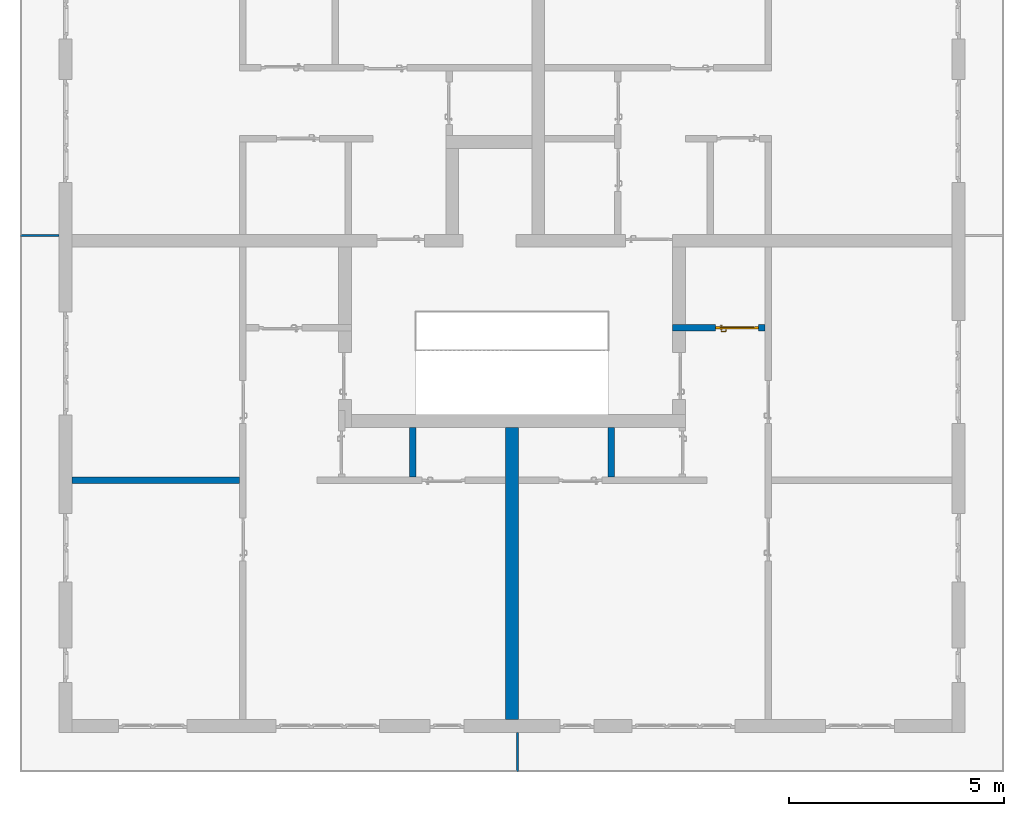
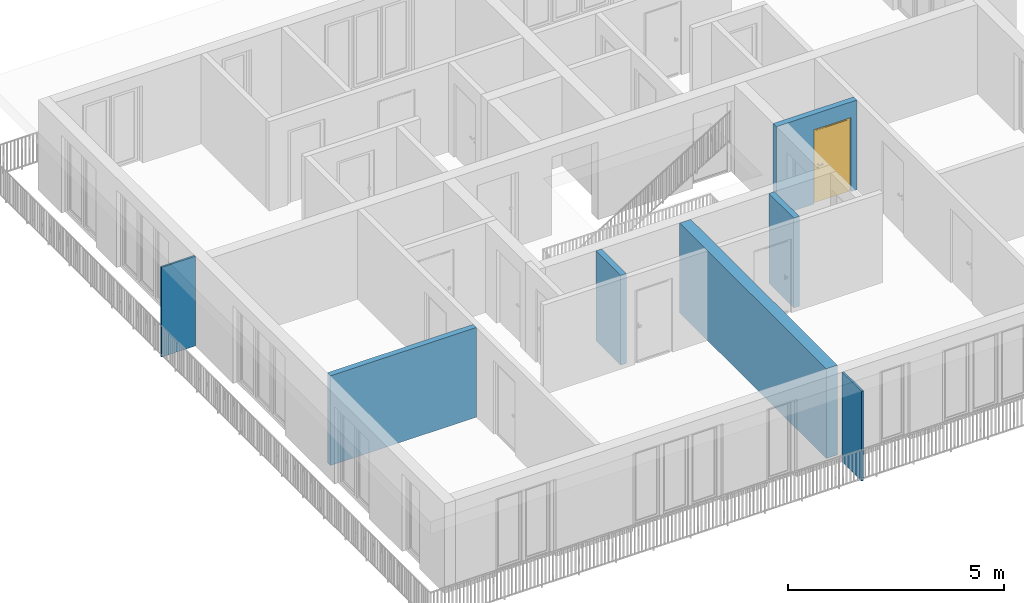
# One storey, part 7 of 54: 7 walls, 1 door, 1 opening.
"""IFC4 building model written with IfcOpenShell, lengths in metres."""

from ifc_helpers import new_model, entity, si_unit, converted_unit, derived_unit, direction, frame, origin_with_axes, place, context, subcontext, project, spatial, polygons, source, transform, mapped, material, type_object, element, fill, save


model = new_model("IFC4")

# Units and contexts
model_context = context("Model", 3, precision=1e-05, world=origin_with_axes(), true_north=direction((0.0, 1.0)))
body_context = subcontext(model_context, "Body", "Model", "MODEL_VIEW")
ifc_project = project(units=[si_unit("LENGTHUNIT", "METRE"), si_unit("AREAUNIT", "SQUARE_METRE"), si_unit("VOLUMEUNIT", "CUBIC_METRE"), converted_unit("PLANEANGLEUNIT", "DEGREE", entity("IfcPlaneAngleMeasure", 0.0174532925199), si_unit("PLANEANGLEUNIT", "RADIAN"), dimensions=[0, 0, 0, 0, 0, 0, 0]), converted_unit("TIMEUNIT", "Year", entity("IfcTimeMeasure", 31556926.0), si_unit("TIMEUNIT", "SECOND"), dimensions=[0, 0, 1, 0, 0, 0, 0]), si_unit("MASSUNIT", "GRAM", prefix="KILO"), si_unit("THERMODYNAMICTEMPERATUREUNIT", "DEGREE_CELSIUS"), si_unit("LUMINOUSINTENSITYUNIT", "LUMEN"), si_unit("ENERGYUNIT", "JOULE", prefix="MEGA"), derived_unit("THERMALCONDUCTANCEUNIT", [(si_unit("POWERUNIT", "WATT"), 1), (si_unit("LENGTHUNIT", "METRE"), -1), (si_unit("THERMODYNAMICTEMPERATUREUNIT", "KELVIN"), -1)]), derived_unit("SPECIFICHEATCAPACITYUNIT", [(si_unit("ENERGYUNIT", "JOULE"), 1), (si_unit("MASSUNIT", "GRAM", prefix="KILO"), -1), (si_unit("THERMODYNAMICTEMPERATUREUNIT", "KELVIN"), -1)]), derived_unit("MASSDENSITYUNIT", [(si_unit("MASSUNIT", "GRAM", prefix="KILO"), 1), (si_unit("VOLUMEUNIT", "CUBIC_METRE"), -1)])], contexts=[model_context])

# Site, building, storey
site_placement = place(None, origin_with_axes())
site = spatial("IfcSite", under=ifc_project, at=site_placement, CompositionType="ELEMENT")
building_placement = place(site_placement, origin_with_axes())
building = spatial("IfcBuilding", under=site, at=building_placement, CompositionType="ELEMENT")
storey_placement = place(building_placement, frame((0.0, 0.0, 6.29), z_axis=(0.0, 0.0, 1.0), x_axis=(1.0, 0.0, 0.0)))
storey = spatial("IfcBuildingStorey", under=building, at=storey_placement, Name="2. Geschoss", CompositionType="ELEMENT", Elevation=6.29)

# Walls
ifc_material_1 = material()
wall_type_1 = type_object("IfcWallType", Name="300", PredefinedType="NOTDEFINED")
wall_1_placement = place(storey_placement, frame((-1.2021993804, -2.52881223104, 0.0), z_axis=(0.0, 0.0, 1.0), x_axis=(0.0, -1.0, 0.0)))
element("IfcWall", 1, at=wall_1_placement, inside=storey, type_object=wall_type_1, material=ifc_material_1, Name="Wand-001", PredefinedType="NOTDEFINED", context=body_context, shape_type="Tessellation", body=[
    polygons([(0.3, -0.15, 0.0), (0.3, -0.15, 2.54), (0.3, 0.15, 2.54), (0.3, 0.15, 0.0), (7.1, -0.15, 0.0), (7.1, -0.15, 2.54), (7.1, 0.15, 2.54), (7.1, 0.15, 0.0)], [[[1, 2, 3, 4]], [[5, 6, 2, 1]], [[6, 7, 3, 2]], [[4, 3, 7, 8]], [[1, 4, 8, 5]], [[8, 7, 6, 5]]], closed=True),
])
wall_type_2 = type_object("IfcWallType", Name="150", PredefinedType="NOTDEFINED")
wall_2_placement = place(storey_placement, frame((-11.7421993804, -4.12881223104, 0.0), z_axis=(0.0, 0.0, 1.0), x_axis=(1.0, 0.0, 0.0)))
element("IfcWall", 2, at=wall_2_placement, inside=storey, type_object=wall_type_2, material=ifc_material_1, Name="Wand-004", PredefinedType="NOTDEFINED", context=body_context, shape_type="Tessellation", body=[
    polygons([(0.3, 0.15, 0.0), (0.3, 0.15, 2.54), (4.2, 0.15, 2.54), (4.2, 0.15, 0.0), (0.3, 0.0, 0.0), (0.3, 0.0, 2.54), (4.2, 0.0, 2.54), (4.2, 0.0, 0.0)], [[[1, 2, 3, 4]], [[5, 6, 2, 1]], [[6, 7, 3, 2]], [[4, 3, 7, 8]], [[1, 4, 8, 5]], [[8, 7, 6, 5]]], closed=True),
])
wall_3_placement = place(storey_placement, frame((-3.5921993804, -4.12881223104, 0.0), z_axis=(0.0, 0.0, 1.0), x_axis=(0.0, 1.0, 0.0)))
element("IfcWall", 3, at=wall_3_placement, inside=storey, type_object=wall_type_2, material=ifc_material_1, Name="Wand-002", PredefinedType="NOTDEFINED", context=body_context, shape_type="Tessellation", body=[
    polygons([(1.3, 0.0, 0.0), (1.3, 0.0, 2.54), (1.3, -0.15, 2.54), (1.3, -0.15, 0.0), (0.15, 0.0, 0.0), (0.15, 0.0, 2.54), (0.15, -0.15, 2.54), (0.15, -0.15, 0.0)], [[[1, 2, 3, 4]], [[5, 6, 2, 1]], [[6, 7, 3, 2]], [[4, 3, 7, 8]], [[5, 1, 4, 8]], [[8, 7, 6, 5]]], closed=True),
])
wall_4_placement = place(storey_placement, frame((1.1878006196, -4.12881223104, 0.0), z_axis=(0.0, 0.0, 1.0), x_axis=(0.0, 1.0, 0.0)))
element("IfcWall", 4, at=wall_4_placement, inside=storey, type_object=wall_type_2, material=ifc_material_1, Name="Wand-002", PredefinedType="NOTDEFINED", context=body_context, shape_type="Tessellation", body=[
    polygons([(1.3, 0.15, 0.0), (1.3, 0.15, 2.54), (1.3, 0.0, 2.54), (1.3, 0.0, 0.0), (0.15, 0.15, 0.0), (0.15, 0.15, 2.54), (0.15, 0.0, 2.54), (0.15, 0.0, 0.0)], [[[1, 2, 3, 4]], [[5, 6, 2, 1]], [[6, 7, 3, 2]], [[4, 3, 7, 8]], [[5, 1, 4, 8]], [[8, 7, 6, 5]]], closed=True),
])

# Wall, opening, door
wall_5_placement = place(storey_placement, frame((2.5378006196, -0.428812231043, 0.0), z_axis=(0.0, 0.0, 1.0), x_axis=(1.0, 0.0, 0.0)))
wall_5 = element("IfcWall", 5, at=wall_5_placement, inside=storey, type_object=wall_type_2, material=ifc_material_1, Name="Wand-002", PredefinedType="NOTDEFINED", context=body_context, shape_type="Tessellation", body=[
    polygons([(2.0, -0.05, 0.0), (2.0, -0.15, 0.0), (2.0, -0.15, 2.1), (2.0, 0.0, 2.1), (2.0, 0.0, 0.0), (2.15, 0.0, 0.0), (2.15, -0.15, 0.0), (2.15, -0.15, 2.54), (0.0, -0.15, 2.54), (0.0, -0.15, 0.0), (1.0, -0.15, 0.0), (1.0, -0.15, 2.1), (1.0, 0.0, 2.1), (1.0, 0.0, 0.0), (0.0, 0.0, 0.0), (0.0, 0.0, 2.54), (2.15, 0.0, 2.54), (1.0, -0.05, 0.0)], [[[1, 2, 3, 4, 5]], [[2, 1, 5, 6, 7]], [[3, 2, 7, 8, 9, 10, 11, 12]], [[4, 3, 12, 13]], [[6, 5, 4, 13, 14, 15, 16, 17]], [[8, 7, 6, 17]], [[17, 16, 9, 8]], [[16, 15, 10, 9]], [[18, 11, 10, 15, 14]], [[12, 11, 18, 14, 13]]], closed=True),
])
opening_placement = place(wall_5_placement, frame((1.5, 0.0, 0.0), z_axis=(0.0, 0.0, 1.0), x_axis=(1.0, 0.0, 0.0)))
opening = element("IfcOpeningElement", 6, at=opening_placement, cuts=wall_5, context=body_context, identifier="Reference", shape_type="Tessellation", body=[
    polygons([(-0.5, -0.05, 0.0), (-0.5, -0.05, 2.1), (-0.5, 0.001, 2.1), (-0.5, 0.001, 0.0), (-0.5, -0.151, 0.0), (-0.5, -0.151, 2.1), (0.5, -0.05, 2.1), (0.5, 0.001, 2.1), (0.5, -0.151, 2.1), (0.5, 0.001, 0.0), (0.5, -0.05, 0.0), (0.5, -0.151, 0.0)], [[[1, 2, 3, 4]], [[2, 1, 5, 6]], [[7, 8, 3, 2, 6, 9]], [[8, 10, 4, 3]], [[1, 4, 10, 11, 12, 5]], [[6, 5, 12, 9]], [[7, 11, 10, 8]], [[11, 7, 9, 12]]], closed=True),
])
door_type = type_object("IfcDoorType", Name="Eingang 01 1-Fl 26", OperationType="SINGLE_SWING_LEFT", PredefinedType="DOOR")
shared_shape = source(origin_with_axes(), body_context, "Body", "Tessellation", [
    polygons([(-0.5, -0.05, 0.0), (-0.5, -0.05, 2.1), (-0.5, -0.03, 2.1), (-0.5, -0.03, 0.0), (-0.4, -0.05, 0.0), (-0.4, -0.05, 2.0), (-0.1301, -0.05, 2.0), (-0.0001, -0.05, 2.0), (0.4, -0.05, 2.0), (0.4, -0.05, 0.0), (0.5, -0.05, 0.0), (0.5, -0.05, 2.1), (0.5, -0.03, 2.1), (0.5, -0.03, 0.0), (0.4, -0.03, 0.0), (0.4, -0.03, 2.0), (-0.0001, -0.03, 2.0), (-0.1301, -0.03, 2.0), (-0.4, -0.03, 2.0), (-0.4, -0.03, 0.0)], [[[1, 2, 3, 4]], [[1, 5, 6, 7, 8, 9, 10, 11, 12, 2]], [[2, 12, 13, 3]], [[4, 3, 13, 14, 15, 16, 17, 18, 19, 20]], [[5, 1, 4, 20]], [[6, 5, 20, 19]], [[7, 6, 19, 18]], [[8, 7, 18, 17]], [[9, 8, 17, 16]], [[10, 9, 16, 15]], [[11, 10, 15, 14]], [[12, 11, 14, 13]]], closed=True),
    polygons([(-0.5, -0.03, 0.0), (-0.5, -0.03, 2.1), (-0.5, 0.0, 2.1), (-0.5, 0.0, 0.0), (-0.43, -0.03, 0.0), (-0.43, -0.03, 2.03), (-0.1001, -0.03, 2.03), (-0.0301, -0.03, 2.03), (0.43, -0.03, 2.03), (0.43, -0.03, 0.0), (0.5, -0.03, 0.0), (0.5, -0.03, 2.1), (0.5, 0.0, 2.1), (0.5, 0.0, 0.0), (0.43, 0.0, 0.0), (0.43, 0.0, 2.03), (-0.0301, 0.0, 2.03), (-0.1001, 0.0, 2.03), (-0.43, 0.0, 2.03), (-0.43, 0.0, 0.0)], [[[1, 2, 3, 4]], [[1, 5, 6, 7, 8, 9, 10, 11, 12, 2]], [[2, 12, 13, 3]], [[4, 3, 13, 14, 15, 16, 17, 18, 19, 20]], [[5, 1, 4, 20]], [[6, 5, 20, 19]], [[7, 6, 19, 18]], [[8, 7, 18, 17]], [[9, 8, 17, 16]], [[10, 9, 16, 15]], [[11, 10, 15, 14]], [[12, 11, 14, 13]]], closed=True),
    polygons([(-0.43, 0.01, 0.0), (-0.43, 0.01, 2.03), (0.43, 0.01, 2.03), (0.43, 0.01, 0.0), (-0.43, -0.03, 0.0), (-0.43, -0.03, 2.03), (0.43, -0.03, 2.03), (0.43, -0.03, 0.0)], [[[1, 2, 3, 4]], [[1, 5, 6, 2]], [[2, 6, 7, 3]], [[3, 7, 8, 4]], [[4, 8, 5, 1]], [[8, 7, 6, 5]]], closed=True),
    polygons([(-0.395, -0.05, 0.0), (0.395, -0.05, 0.0), (0.395, -0.05, 0.05), (-0.395, -0.05, 0.05), (-0.395, -0.03, 0.0), (0.395, -0.03, 0.0), (0.395, -0.03, 0.07), (0.395, -0.035, 0.07), (-0.395, -0.035, 0.07), (-0.395, -0.03, 0.07)], [[[1, 2, 3, 4]], [[5, 6, 2, 1]], [[2, 6, 7, 8, 3]], [[4, 3, 8, 9]], [[1, 4, 9, 10, 5]], [[10, 7, 6, 5]], [[9, 8, 7, 10]]], closed=True),
    polygons([(0.3835, 0.02, 1.0733826859), (0.37, 0.02, 1.077), (0.37, 0.0199, 1.077), (0.3835, 0.0199, 1.0733826859), (0.393382685902, 0.02, 1.0635), (0.397, 0.02, 1.05), (0.393382685902, 0.02, 1.0365), (0.3835, 0.02, 1.0266173141), (0.37, 0.02, 1.023), (0.3565, 0.02, 1.0266173141), (0.346617314098, 0.02, 1.0365), (0.343, 0.02, 1.05), (0.346617314098, 0.02, 1.0635), (0.3565, 0.02, 1.0733826859), (0.3565, 0.0199, 1.0733826859), (0.37, 0.0101, 1.077), (0.3835, 0.0101, 1.0733826859), (0.393382685902, 0.0199, 1.0635), (0.397, 0.0199, 1.05), (0.393382685902, 0.0199, 1.0365), (0.3835, 0.0199, 1.0266173141), (0.37, 0.0199, 1.023), (0.3565, 0.0199, 1.0266173141), (0.346617314098, 0.0199, 1.0365), (0.343, 0.0199, 1.05), (0.346617314098, 0.0199, 1.0635), (0.3565, 0.0101, 1.0733826859), (0.37, 0.01, 1.077), (0.3835, 0.01, 1.0733826859), (0.393382685902, 0.0101, 1.0635), (0.397, 0.0101, 1.05), (0.393382685902, 0.0101, 1.0365), (0.3835, 0.0101, 1.0266173141), (0.37, 0.0101, 1.023), (0.3565, 0.0101, 1.0266173141), (0.346617314098, 0.0101, 1.0365), (0.343, 0.0101, 1.05), (0.346617314098, 0.0101, 1.0635), (0.3565, 0.01, 1.0733826859), (0.346617314098, 0.01, 1.0635), (0.343, 0.01, 1.05), (0.346617314098, 0.01, 1.0365), (0.3565, 0.01, 1.0266173141), (0.37, 0.01, 1.023), (0.3835, 0.01, 1.0266173141), (0.393382685902, 0.01, 1.0365), (0.397, 0.01, 1.05), (0.393382685902, 0.01, 1.0635)], [[[1, 2, 3, 4]], [[2, 1, 5, 6, 7, 8, 9, 10, 11, 12, 13, 14]], [[2, 14, 15, 3]], [[4, 3, 16, 17]], [[5, 1, 4, 18]], [[6, 5, 18, 19]], [[7, 6, 19, 20]], [[8, 7, 20, 21]], [[9, 8, 21, 22]], [[10, 9, 22, 23]], [[11, 10, 23, 24]], [[12, 11, 24, 25]], [[13, 12, 25, 26]], [[14, 13, 26, 15]], [[3, 15, 27, 16]], [[17, 16, 28, 29]], [[18, 4, 17, 30]], [[19, 18, 30, 31]], [[20, 19, 31, 32]], [[21, 20, 32, 33]], [[22, 21, 33, 34]], [[23, 22, 34, 35]], [[24, 23, 35, 36]], [[25, 24, 36, 37]], [[26, 25, 37, 38]], [[15, 26, 38, 27]], [[16, 27, 39, 28]], [[28, 39, 40, 41, 42, 43, 44, 45, 46, 47, 48, 29]], [[30, 17, 29, 48]], [[31, 30, 48, 47]], [[32, 31, 47, 46]], [[33, 32, 46, 45]], [[34, 33, 45, 44]], [[35, 34, 44, 43]], [[36, 35, 43, 42]], [[37, 36, 42, 41]], [[38, 37, 41, 40]], [[27, 38, 40, 39]]], closed=True),
    polygons([(0.362532169224, 0.019, 0.959692280177), (0.363279754556, 0.019, 0.961639806549), (0.35705, 0.019, 0.972430057958), (0.347569942042, 0.019, 0.96295), (0.365, 0.019, 0.952886751346), (0.365, 0.019, 0.9544), (0.362532169224, 0.02, 0.959692280177), (0.363279754556, 0.02, 0.961639806549), (0.364624817685, 0.02, 0.965143815798), (0.364624817685, 0.019, 0.965143815798), (0.37, 0.019, 0.967425445323), (0.37, 0.019, 0.9759), (0.357, 0.019, 0.972516660498), (0.347483339502, 0.019, 0.963), (0.365, 0.019, 0.95), (0.3441, 0.019, 0.95), (0.365, 0.019, 0.947113248654), (0.365, 0.019, 0.941339745962), (0.365, 0.019, 0.9375), (0.365, 0.02, 0.9375), (0.365, 0.02, 0.941339745962), (0.365, 0.02, 0.947113248654), (0.365, 0.02, 0.95), (0.365, 0.02, 0.952886751346), (0.365, 0.02, 0.9544), (0.346703916638, 0.02, 0.96345), (0.35655, 0.02, 0.973296083362), (0.37, 0.02, 0.9769), (0.37, 0.02, 0.967425445323), (0.375375182315, 0.019, 0.965143815798), (0.376720245444, 0.019, 0.961639806549), (0.38295, 0.019, 0.972430057958), (0.37, 0.019, 0.976), (0.357, 0.0189, 0.972516660498), (0.347483339502, 0.0189, 0.963), (0.344, 0.019, 0.95), (0.347569942042, 0.019, 0.93705), (0.35705, 0.019, 0.927569942042), (0.37, 0.019, 0.9241), (0.37, 0.019, 0.9325), (0.366464466094, 0.019, 0.933964466094), (0.366464466094, 0.02, 0.933964466094), (0.37, 0.02, 0.9231), (0.35655, 0.02, 0.926703916638), (0.37, 0.02, 0.9325), (0.346703916638, 0.02, 0.93655), (0.3431, 0.02, 0.95), (0.346617314098, 0.02, 0.9635), (0.3565, 0.02, 0.973382685902), (0.37, 0.02, 0.977), (0.375375182315, 0.02, 0.965143815798), (0.38345, 0.02, 0.973296083362), (0.376720245444, 0.02, 0.961639806549), (0.377467830776, 0.02, 0.959692280177), (0.377467830776, 0.019, 0.959692280177), (0.375, 0.019, 0.9544), (0.375, 0.019, 0.952886751346), (0.392430057958, 0.019, 0.96295), (0.383, 0.019, 0.972516660498), (0.37, 0.0189, 0.976), (0.357, 0.0101, 0.972516660498), (0.347483339502, 0.0101, 0.963), (0.344, 0.0189, 0.95), (0.347483339502, 0.019, 0.937), (0.357, 0.019, 0.927483339502), (0.37, 0.019, 0.924), (0.38295, 0.019, 0.927569942042), (0.375, 0.019, 0.941339745962), (0.375, 0.019, 0.9375), (0.373535533906, 0.019, 0.933964466094), (0.37, 0.02, 0.923), (0.3565, 0.02, 0.926617314098), (0.38345, 0.02, 0.926703916638), (0.373535533906, 0.02, 0.933964466094), (0.375, 0.02, 0.9375), (0.375, 0.02, 0.941339745962), (0.346617314098, 0.02, 0.9365), (0.343, 0.02, 0.95), (0.346617314098, 0.0199, 0.9635), (0.3565, 0.0199, 0.973382685902), (0.37, 0.0199, 0.977), (0.3835, 0.02, 0.973382685902), (0.393296083362, 0.02, 0.96345), (0.375, 0.02, 0.952886751346), (0.375, 0.02, 0.9544), (0.375, 0.02, 0.95), (0.375, 0.02, 0.947113248654), (0.375, 0.019, 0.947113248654), (0.375, 0.019, 0.95), (0.3959, 0.019, 0.95), (0.392516660498, 0.019, 0.963), (0.383, 0.0189, 0.972516660498), (0.37, 0.0101, 0.976), (0.357, 0.01, 0.972516660498), (0.347483339502, 0.01, 0.963), (0.344, 0.0101, 0.95), (0.347483339502, 0.0189, 0.937), (0.357, 0.0189, 0.927483339502), (0.37, 0.0189, 0.924), (0.383, 0.019, 0.927483339502), (0.392430057958, 0.019, 0.93705), (0.37, 0.0199, 0.923), (0.3565, 0.0199, 0.926617314098), (0.3835, 0.02, 0.926617314098), (0.393296083362, 0.02, 0.93655), (0.346617314098, 0.0199, 0.9365), (0.343, 0.0199, 0.95), (0.346617314098, 0.0101, 0.9635), (0.3565, 0.0101, 0.973382685902), (0.37, 0.0101, 0.977), (0.3835, 0.0199, 0.973382685902), (0.393382685902, 0.02, 0.9635), (0.3969, 0.02, 0.95), (0.396, 0.019, 0.95), (0.392516660498, 0.0189, 0.963), (0.383, 0.0101, 0.972516660498), (0.37, 0.01, 0.976), (0.35695, 0.01, 0.972603263039), (0.347396736961, 0.01, 0.96305), (0.344, 0.01, 0.95), (0.347483339502, 0.0101, 0.937), (0.357, 0.0101, 0.927483339502), (0.37, 0.0101, 0.924), (0.383, 0.0189, 0.927483339502), (0.392516660498, 0.019, 0.937), (0.37, 0.0101, 0.923), (0.3565, 0.0101, 0.926617314098), (0.3835, 0.0199, 0.926617314098), (0.393382685902, 0.02, 0.9365), (0.346617314098, 0.0101, 0.9365), (0.343, 0.0101, 0.95), (0.346617314098, 0.01, 0.9635), (0.3565, 0.01, 0.973382685902), (0.37, 0.01, 0.977), (0.3835, 0.0101, 0.973382685902), (0.393382685902, 0.0199, 0.9635), (0.397, 0.02, 0.95), (0.396, 0.0189, 0.95), (0.392516660498, 0.0101, 0.963), (0.383, 0.01, 0.972516660498), (0.37, 0.01, 0.9761), (0.35655, 0.01, 0.973296083362), (0.346703916638, 0.01, 0.96345), (0.3439, 0.01, 0.95), (0.347483339502, 0.01, 0.937), (0.357, 0.01, 0.927483339502), (0.37, 0.01, 0.924), (0.383, 0.0101, 0.927483339502), (0.392516660498, 0.0189, 0.937), (0.37, 0.01, 0.923), (0.3565, 0.01, 0.926617314098), (0.3835, 0.0101, 0.926617314098), (0.393382685902, 0.0199, 0.9365), (0.346617314098, 0.01, 0.9365), (0.343, 0.01, 0.95), (0.37, 0.01, 0.9769), (0.3835, 0.01, 0.973382685902), (0.393382685902, 0.0101, 0.9635), (0.397, 0.0199, 0.95), (0.396, 0.0101, 0.95), (0.392516660498, 0.01, 0.963), (0.38305, 0.01, 0.972603263039), (0.3431, 0.01, 0.95), (0.347396736961, 0.01, 0.93695), (0.35695, 0.01, 0.927396736961), (0.37, 0.01, 0.9239), (0.383, 0.01, 0.927483339502), (0.392516660498, 0.0101, 0.937), (0.37, 0.01, 0.9231), (0.35655, 0.01, 0.926703916638), (0.3835, 0.01, 0.926617314098), (0.393382685902, 0.0101, 0.9365), (0.346703916638, 0.01, 0.93655), (0.38345, 0.01, 0.973296083362), (0.393382685902, 0.01, 0.9635), (0.397, 0.0101, 0.95), (0.396, 0.01, 0.95), (0.392603263039, 0.01, 0.96305), (0.38305, 0.01, 0.927396736961), (0.392516660498, 0.01, 0.937), (0.38345, 0.01, 0.926703916638), (0.393382685902, 0.01, 0.9365), (0.393296083362, 0.01, 0.96345), (0.397, 0.01, 0.95), (0.3961, 0.01, 0.95), (0.392603263039, 0.01, 0.93695), (0.393296083362, 0.01, 0.93655), (0.3969, 0.01, 0.95)], [[[1, 2, 3, 4, 5, 6]], [[1, 7, 8, 9, 10, 2]], [[10, 11, 12, 3, 2]], [[4, 3, 13, 14]], [[15, 5, 4, 16]], [[6, 5, 15, 17, 18, 19, 20, 21, 22, 23, 24, 25]], [[6, 25, 7, 1]], [[7, 25, 24, 26, 27, 8]], [[9, 8, 27, 28, 29]], [[10, 9, 29, 11]], [[30, 31, 32, 12, 11]], [[3, 12, 33, 13]], [[14, 13, 34, 35]], [[16, 4, 14, 36]], [[17, 15, 16, 37]], [[18, 17, 37, 38]], [[38, 39, 40, 41, 19, 18]], [[19, 41, 42, 20]], [[43, 44, 21, 20, 42, 45]], [[22, 21, 44, 46]], [[23, 22, 46, 47]], [[24, 23, 47, 26]], [[48, 49, 27, 26]], [[49, 50, 28, 27]], [[51, 29, 28, 52, 53]], [[11, 29, 51, 30]], [[30, 51, 53, 54, 55, 31]], [[55, 56, 57, 58, 32, 31]], [[12, 32, 59, 33]], [[13, 33, 60, 34]], [[35, 34, 61, 62]], [[36, 14, 35, 63]], [[37, 16, 36, 64]], [[38, 37, 64, 65]], [[39, 38, 65, 66]], [[39, 67, 68, 69, 70, 40]], [[41, 40, 45, 42]], [[71, 72, 44, 43]], [[73, 43, 45, 74, 75, 76]], [[72, 77, 46, 44]], [[77, 78, 47, 46]], [[78, 48, 26, 47]], [[79, 80, 49, 48]], [[80, 81, 50, 49]], [[50, 82, 52, 28]], [[54, 53, 52, 83, 84, 85]], [[55, 54, 85, 56]], [[85, 84, 86, 87, 76, 75, 69, 68, 88, 89, 57, 56]], [[57, 89, 90, 58]], [[32, 58, 91, 59]], [[33, 59, 92, 60]], [[34, 60, 93, 61]], [[62, 61, 94, 95]], [[63, 35, 62, 96]], [[64, 36, 63, 97]], [[65, 64, 97, 98]], [[66, 65, 98, 99]], [[67, 39, 66, 100]], [[88, 68, 67, 101]], [[70, 69, 75, 74]], [[40, 70, 74, 45]], [[102, 103, 72, 71]], [[104, 71, 43, 73]], [[76, 87, 105, 73]], [[103, 106, 77, 72]], [[106, 107, 78, 77]], [[107, 79, 48, 78]], [[108, 109, 80, 79]], [[109, 110, 81, 80]], [[81, 111, 82, 50]], [[82, 112, 83, 52]], [[86, 84, 83, 113]], [[87, 86, 113, 105]], [[89, 88, 101, 90]], [[58, 90, 114, 91]], [[59, 91, 115, 92]], [[60, 92, 116, 93]], [[61, 93, 117, 94]], [[95, 94, 118, 119]], [[96, 62, 95, 120]], [[97, 63, 96, 121]], [[98, 97, 121, 122]], [[99, 98, 122, 123]], [[100, 66, 99, 124]], [[101, 67, 100, 125]], [[126, 127, 103, 102]], [[128, 102, 71, 104]], [[129, 104, 73, 105]], [[127, 130, 106, 103]], [[130, 131, 107, 106]], [[131, 108, 79, 107]], [[132, 133, 109, 108]], [[133, 134, 110, 109]], [[110, 135, 111, 81]], [[111, 136, 112, 82]], [[112, 137, 113, 83]], [[137, 129, 105, 113]], [[90, 101, 125, 114]], [[91, 114, 138, 115]], [[92, 115, 139, 116]], [[93, 116, 140, 117]], [[94, 117, 141, 118]], [[119, 118, 142, 143]], [[120, 95, 119, 144]], [[121, 96, 120, 145]], [[122, 121, 145, 146]], [[123, 122, 146, 147]], [[124, 99, 123, 148]], [[125, 100, 124, 149]], [[150, 151, 127, 126]], [[152, 126, 102, 128]], [[153, 128, 104, 129]], [[151, 154, 130, 127]], [[154, 155, 131, 130]], [[155, 132, 108, 131]], [[143, 142, 133, 132]], [[142, 156, 134, 133]], [[134, 157, 135, 110]], [[135, 158, 136, 111]], [[136, 159, 137, 112]], [[159, 153, 129, 137]], [[114, 125, 149, 138]], [[115, 138, 160, 139]], [[116, 139, 161, 140]], [[117, 140, 162, 141]], [[118, 141, 156, 142]], [[144, 119, 143, 163]], [[145, 120, 144, 164]], [[146, 145, 164, 165]], [[147, 146, 165, 166]], [[148, 123, 147, 167]], [[149, 124, 148, 168]], [[169, 170, 151, 150]], [[171, 150, 126, 152]], [[172, 152, 128, 153]], [[170, 173, 154, 151]], [[173, 163, 155, 154]], [[163, 143, 132, 155]], [[156, 174, 157, 134]], [[157, 175, 158, 135]], [[158, 176, 159, 136]], [[176, 172, 153, 159]], [[138, 149, 168, 160]], [[139, 160, 177, 161]], [[140, 161, 178, 162]], [[141, 162, 174, 156]], [[164, 144, 163, 173]], [[165, 164, 173, 170]], [[166, 165, 170, 169]], [[167, 147, 166, 179]], [[168, 148, 167, 180]], [[181, 169, 150, 171]], [[182, 171, 152, 172]], [[174, 183, 175, 157]], [[175, 184, 176, 158]], [[184, 182, 172, 176]], [[160, 168, 180, 177]], [[161, 177, 185, 178]], [[162, 178, 183, 174]], [[179, 166, 169, 181]], [[180, 167, 179, 186]], [[187, 181, 171, 182]], [[183, 188, 184, 175]], [[188, 187, 182, 184]], [[177, 180, 186, 185]], [[178, 185, 188, 183]], [[186, 179, 181, 187]], [[185, 186, 187, 188]]], closed=True),
    polygons([(0.38, 0.02, 1.05), (0.377071067812, 0.02, 1.04292893219), (0.377071067812, 0.050696439392, 1.04292893219), (0.38, 0.0509849140336, 1.05), (0.37, 0.02, 1.04), (0.37, 0.05, 1.04), (0.375518993221, 0.0584992452783, 1.04292893219), (0.378277987014, 0.0596420579258, 1.05), (0.377071067812, 0.02, 1.05707106781), (0.377071067812, 0.050696439392, 1.05707106781), (0.362928932188, 0.02, 1.04292893219), (0.362928932188, 0.049303560608, 1.04292893219), (0.368858192988, 0.0557402514855, 1.04), (0.370704557509, 0.0657045575088, 1.04292893219), (0.372816199938, 0.0678161999379, 1.05), (0.375518993221, 0.0584992452783, 1.05707106781), (0.37, 0.02, 1.06), (0.37, 0.05, 1.06), (0.36, 0.02, 1.05), (0.36, 0.0490150859664, 1.05), (0.362197392755, 0.0529812576926, 1.04292893219), (0.365606601718, 0.0606066017178, 1.04), (0.363499245278, 0.0705189932208, 1.04292893219), (0.364642057926, 0.0732779870137, 1.05), (0.370704557509, 0.0657045575088, 1.05707106781), (0.368858192988, 0.0557402514855, 1.06), (0.362928932188, 0.02, 1.05707106781), (0.362928932188, 0.049303560608, 1.05707106781), (0.359438398962, 0.0518384450452, 1.05), (0.360508645927, 0.0555086459268, 1.04292893219), (0.360740251485, 0.0638581929877, 1.04), (0.355696439392, 0.0720710678119, 1.04292893219), (0.355984914034, 0.075, 1.05), (0.363499245278, 0.0705189932208, 1.05707106781), (0.365606601718, 0.0606066017178, 1.06), (0.362197392755, 0.0529812576926, 1.05707106781), (0.358397003498, 0.0533970034977, 1.05), (0.357981257693, 0.0571973927545, 1.04292893219), (0.355, 0.065, 1.04), (0.274303560608, 0.0720710678119, 1.04292893219), (0.274015085966, 0.075, 1.05), (0.355696439392, 0.0720710678119, 1.05707106781), (0.360740251485, 0.0638581929877, 1.06), (0.360508645927, 0.0555086459268, 1.05707106781), (0.356838445045, 0.0544383989617, 1.05), (0.354303560608, 0.0579289321881, 1.04292893219), (0.275, 0.065, 1.04), (0.266500754722, 0.0705189932208, 1.04292893219), (0.265357942074, 0.0732779870137, 1.05), (0.274303560608, 0.0720710678119, 1.05707106781), (0.355, 0.065, 1.06), (0.357981257693, 0.0571973927545, 1.05707106781), (0.354015085966, 0.055, 1.05), (0.275696439392, 0.0579289321881, 1.04292893219), (0.269259748515, 0.0638581929877, 1.04), (0.259295442491, 0.0657045575088, 1.04292893219), (0.257183800062, 0.0678161999379, 1.05), (0.266500754722, 0.0705189932208, 1.05707106781), (0.275, 0.065, 1.06), (0.354303560608, 0.0579289321881, 1.05707106781), (0.275984914034, 0.055, 1.05), (0.272018742307, 0.0571973927545, 1.04292893219), (0.264393398282, 0.0606066017178, 1.04), (0.254481006779, 0.0584992452783, 1.04292893219), (0.251722012986, 0.0596420579258, 1.05), (0.259295442491, 0.0657045575088, 1.05707106781), (0.269259748515, 0.0638581929877, 1.06), (0.275696439392, 0.0579289321881, 1.05707106781), (0.273161554955, 0.0544383989617, 1.05), (0.269491354073, 0.0555086459268, 1.04292893219), (0.261141807012, 0.0557402514855, 1.04), (0.252928932188, 0.050696439392, 1.04292893219), (0.25, 0.0509849140336, 1.05), (0.254481006779, 0.0584992452783, 1.05707106781), (0.264393398282, 0.0606066017178, 1.06), (0.272018742307, 0.0571973927545, 1.05707106781), (0.271602996502, 0.0533970034977, 1.05), (0.267802607245, 0.0529812576926, 1.04292893219), (0.26, 0.05, 1.04), (0.252928932188, 0.02, 1.04292893219), (0.25, 0.02, 1.05), (0.252928932188, 0.050696439392, 1.05707106781), (0.261141807012, 0.0557402514855, 1.06), (0.269491354073, 0.0555086459268, 1.05707106781), (0.270561601038, 0.0518384450452, 1.05), (0.267071067812, 0.049303560608, 1.04292893219), (0.26, 0.02, 1.04), (0.267071067812, 0.02, 1.04292893219), (0.27, 0.02, 1.05), (0.267071067812, 0.02, 1.05707106781), (0.26, 0.02, 1.06), (0.252928932188, 0.02, 1.05707106781), (0.26, 0.05, 1.06), (0.267802607245, 0.0529812576926, 1.05707106781), (0.27, 0.0490150859664, 1.05), (0.267071067812, 0.049303560608, 1.05707106781)], [[[1, 2, 3, 4]], [[2, 5, 6, 3]], [[4, 3, 7, 8]], [[9, 1, 4, 10]], [[5, 11, 12, 6]], [[3, 6, 13, 7]], [[8, 7, 14, 15]], [[10, 4, 8, 16]], [[17, 9, 10, 18]], [[11, 19, 20, 12]], [[6, 12, 21, 13]], [[7, 13, 22, 14]], [[15, 14, 23, 24]], [[16, 8, 15, 25]], [[18, 10, 16, 26]], [[27, 17, 18, 28]], [[19, 27, 28, 20]], [[12, 20, 29, 21]], [[13, 21, 30, 22]], [[14, 22, 31, 23]], [[24, 23, 32, 33]], [[25, 15, 24, 34]], [[26, 16, 25, 35]], [[28, 18, 26, 36]], [[20, 28, 36, 29]], [[21, 29, 37, 30]], [[22, 30, 38, 31]], [[23, 31, 39, 32]], [[33, 32, 40, 41]], [[34, 24, 33, 42]], [[35, 25, 34, 43]], [[36, 26, 35, 44]], [[29, 36, 44, 37]], [[30, 37, 45, 38]], [[31, 38, 46, 39]], [[32, 39, 47, 40]], [[41, 40, 48, 49]], [[42, 33, 41, 50]], [[43, 34, 42, 51]], [[44, 35, 43, 52]], [[37, 44, 52, 45]], [[38, 45, 53, 46]], [[39, 46, 54, 47]], [[40, 47, 55, 48]], [[49, 48, 56, 57]], [[50, 41, 49, 58]], [[51, 42, 50, 59]], [[52, 43, 51, 60]], [[45, 52, 60, 53]], [[46, 53, 61, 54]], [[47, 54, 62, 55]], [[48, 55, 63, 56]], [[57, 56, 64, 65]], [[58, 49, 57, 66]], [[59, 50, 58, 67]], [[60, 51, 59, 68]], [[53, 60, 68, 61]], [[54, 61, 69, 62]], [[55, 62, 70, 63]], [[56, 63, 71, 64]], [[65, 64, 72, 73]], [[66, 57, 65, 74]], [[67, 58, 66, 75]], [[68, 59, 67, 76]], [[61, 68, 76, 69]], [[62, 69, 77, 70]], [[63, 70, 78, 71]], [[64, 71, 79, 72]], [[73, 72, 80, 81]], [[74, 65, 73, 82]], [[75, 66, 74, 83]], [[76, 67, 75, 84]], [[69, 76, 84, 77]], [[70, 77, 85, 78]], [[71, 78, 86, 79]], [[72, 79, 87, 80]], [[81, 80, 87, 88, 89, 90, 91, 92]], [[82, 73, 81, 92]], [[83, 74, 82, 93]], [[84, 75, 83, 94]], [[77, 84, 94, 85]], [[78, 85, 95, 86]], [[79, 86, 88, 87]], [[86, 95, 89, 88]], [[95, 96, 90, 89]], [[96, 93, 91, 90]], [[93, 82, 92, 91]], [[94, 83, 93, 96]], [[85, 94, 96, 95]]], closed=False),
    polygons([(0.364696699141, -0.035, 1.04469669914), (0.3625, -0.035, 1.05), (0.364696699141, -0.035, 1.05530330086), (0.37, -0.035, 1.0575), (0.375303300859, -0.035, 1.05530330086), (0.3775, -0.035, 1.05), (0.375303300859, -0.035, 1.04469669914), (0.37, -0.035, 1.0425), (0.364696699141, -0.075, 1.04469669914), (0.3625, -0.075, 1.05), (0.364696699141, -0.075, 1.05530330086), (0.37, -0.075, 1.0575), (0.375303300859, -0.075, 1.05530330086), (0.3775, -0.075, 1.05), (0.375303300859, -0.075, 1.04469669914), (0.37, -0.075, 1.0425)], [[[1, 2, 3, 4, 5, 6, 7, 8]], [[1, 9, 10, 2]], [[2, 10, 11, 3]], [[3, 11, 12, 4]], [[4, 12, 13, 5]], [[5, 13, 14, 6]], [[6, 14, 15, 7]], [[7, 15, 16, 8]], [[8, 16, 9, 1]], [[9, 16, 15, 14, 13, 12, 11, 10]]], closed=True),
    polygons([(0.395, -0.03, 0.975), (0.395, -0.035, 0.975), (0.393096988313, -0.035, 0.965432914191), (0.393096988313, -0.03, 0.965432914191), (0.395, -0.03, 1.1), (0.395, -0.035, 1.1), (0.393096988313, -0.035, 1.10956708581), (0.38767766953, -0.035, 1.11767766953), (0.379567085809, -0.035, 1.12309698831), (0.37, -0.035, 1.125), (0.360432914191, -0.035, 1.12309698831), (0.35232233047, -0.035, 1.11767766953), (0.346903011687, -0.035, 1.10956708581), (0.345, -0.035, 1.1), (0.345, -0.035, 0.975), (0.346903011687, -0.035, 0.965432914191), (0.35232233047, -0.035, 0.95732233047), (0.360432914191, -0.035, 0.951903011687), (0.37, -0.035, 0.95), (0.379567085809, -0.035, 0.951903011687), (0.38767766953, -0.035, 0.95732233047), (0.38767766953, -0.03, 0.95732233047), (0.379567085809, -0.03, 0.951903011687), (0.37, -0.03, 0.95), (0.360432914191, -0.03, 0.951903011687), (0.35232233047, -0.03, 0.95732233047), (0.346903011687, -0.03, 0.965432914191), (0.345, -0.03, 0.975), (0.345, -0.03, 1.1), (0.346903011687, -0.03, 1.10956708581), (0.35232233047, -0.03, 1.11767766953), (0.360432914191, -0.03, 1.12309698831), (0.37, -0.03, 1.125), (0.379567085809, -0.03, 1.12309698831), (0.38767766953, -0.03, 1.11767766953), (0.393096988313, -0.03, 1.10956708581)], [[[1, 2, 3, 4]], [[5, 6, 2, 1]], [[2, 6, 7, 8, 9, 10, 11, 12, 13, 14, 15, 16, 17, 18, 19, 20, 21, 3]], [[4, 3, 21, 22]], [[1, 4, 22, 23, 24, 25, 26, 27, 28, 29, 30, 31, 32, 33, 34, 35, 36, 5]], [[36, 7, 6, 5]], [[35, 8, 7, 36]], [[34, 9, 8, 35]], [[33, 10, 9, 34]], [[32, 11, 10, 33]], [[31, 12, 11, 32]], [[30, 13, 12, 31]], [[29, 14, 13, 30]], [[28, 15, 14, 29]], [[27, 16, 15, 28]], [[26, 17, 16, 27]], [[25, 18, 17, 26]], [[24, 19, 18, 25]], [[23, 20, 19, 24]], [[22, 21, 20, 23]]], closed=True),
    polygons([(0.39, -0.075, 1.08), (0.39, -0.09, 1.08), (0.395, -0.09, 1.07866025404), (0.395, -0.075, 1.07866025404), (0.35, -0.075, 1.08), (0.35, -0.09, 1.08), (0.345, -0.09, 1.07866025404), (0.341339745962, -0.09, 1.075), (0.34, -0.09, 1.07), (0.34, -0.09, 1.03), (0.341339745962, -0.09, 1.025), (0.345, -0.09, 1.02133974596), (0.35, -0.09, 1.02), (0.39, -0.09, 1.02), (0.395, -0.09, 1.02133974596), (0.398660254038, -0.09, 1.025), (0.4, -0.09, 1.03), (0.4, -0.09, 1.07), (0.398660254038, -0.09, 1.075), (0.398660254038, -0.075, 1.075), (0.4, -0.075, 1.07), (0.4, -0.075, 1.03), (0.398660254038, -0.075, 1.025), (0.395, -0.075, 1.02133974596), (0.39, -0.075, 1.02), (0.35, -0.075, 1.02), (0.345, -0.075, 1.02133974596), (0.341339745962, -0.075, 1.025), (0.34, -0.075, 1.03), (0.34, -0.075, 1.07), (0.341339745962, -0.075, 1.075), (0.345, -0.075, 1.07866025404)], [[[1, 2, 3, 4]], [[5, 6, 2, 1]], [[2, 6, 7, 8, 9, 10, 11, 12, 13, 14, 15, 16, 17, 18, 19, 3]], [[4, 3, 19, 20]], [[1, 4, 20, 21, 22, 23, 24, 25, 26, 27, 28, 29, 30, 31, 32, 5]], [[32, 7, 6, 5]], [[31, 8, 7, 32]], [[30, 9, 8, 31]], [[29, 10, 9, 30]], [[28, 11, 10, 29]], [[27, 12, 11, 28]], [[26, 13, 12, 27]], [[25, 14, 13, 26]], [[24, 15, 14, 25]], [[23, 16, 15, 24]], [[22, 17, 16, 23]], [[21, 18, 17, 22]], [[20, 19, 18, 21]]], closed=True),
])
door_placement = place(opening_placement, frame((0.4, 0.0, 0.0), z_axis=(0.0, 0.0, 1.0), x_axis=(-1.0, 0.0, 0.0)))
door = element("IfcDoor", 7, at=door_placement, inside=storey, type_object=door_type, OverallHeight=2.1, OverallWidth=1.0, PredefinedType="DOOR", context=body_context, shape_type="MappedRepresentation", body=[
    mapped(shared_shape, transform((0.4, 0.1, 0.0))),
])
fill(opening, door)

# Walls
ifc_material_2 = material()
wall_type_3 = type_object("IfcWallType", Name="50", PredefinedType="NOTDEFINED")
wall_6_placement = place(storey_placement, frame((-1.0521993804, -9.62881223104, 0.0), z_axis=(0.0, 0.0, 1.0), x_axis=(0.0, -1.0, 0.0)))
element("IfcWall", 8, at=wall_6_placement, inside=storey, type_object=wall_type_3, material=ifc_material_2, Name="Wand-003", PredefinedType="NOTDEFINED", context=body_context, shape_type="Tessellation", body=[
    polygons([(0.3, -0.05, 2.54), (0.3, 0.0, 2.54), (0.3, 0.0, 0.0), (0.3, -0.05, 0.0), (1.2, 0.0, 2.54), (1.2, -0.05, 2.54), (1.2, 0.0, 0.0), (1.2, -0.05, 0.0)], [[[1, 2, 3, 4]], [[5, 2, 1, 6]], [[2, 5, 7, 3]], [[3, 7, 8, 4]], [[6, 1, 4, 8]], [[5, 6, 8, 7]]], closed=True),
])
wall_7_placement = place(storey_placement, frame((-12.6421993804, 1.67118776896, 0.0), z_axis=(0.0, 0.0, 1.0), x_axis=(1.0, 0.0, 0.0)))
element("IfcWall", 9, at=wall_7_placement, inside=storey, type_object=wall_type_3, material=ifc_material_2, Name="Wand-003", PredefinedType="NOTDEFINED", context=body_context, shape_type="Tessellation", body=[
    polygons([(0.0, 0.0, 2.54), (0.9, 0.0, 2.54), (0.9, 0.0, 0.0), (0.0, 0.0, 0.0), (0.9, -0.05, 2.54), (0.0, -0.05, 2.54), (0.9, -0.05, 0.0), (0.0, -0.05, 0.0)], [[[1, 2, 3, 4]], [[5, 2, 1, 6]], [[2, 5, 7, 3]], [[3, 7, 8, 4]], [[6, 1, 4, 8]], [[5, 6, 8, 7]]], closed=True),
])

save(model, "model.ifc")
